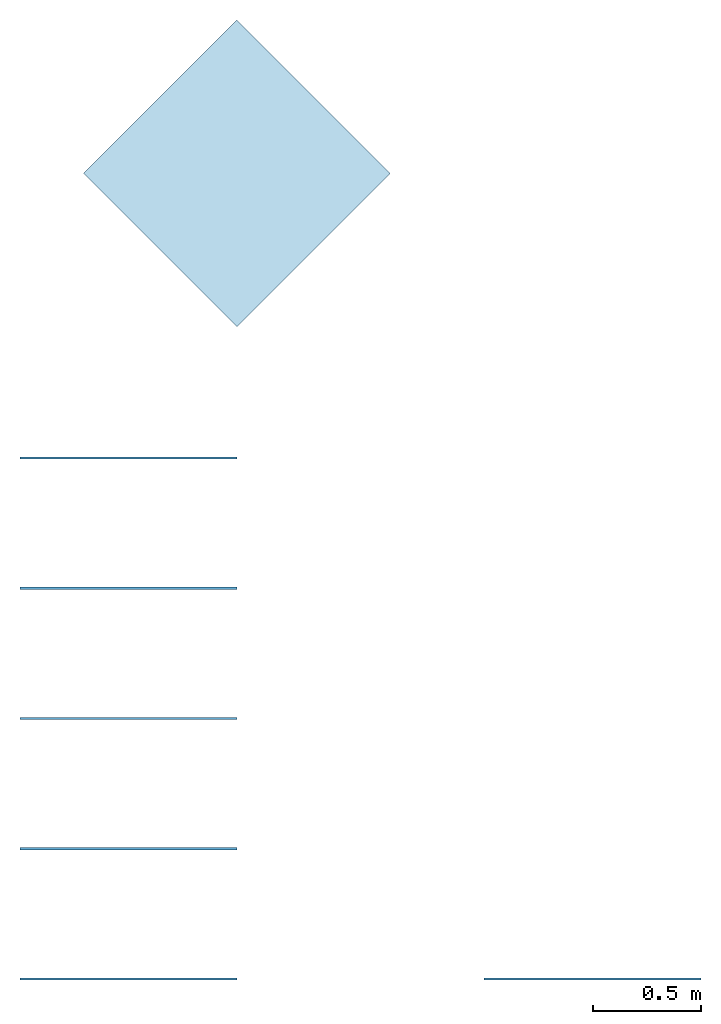
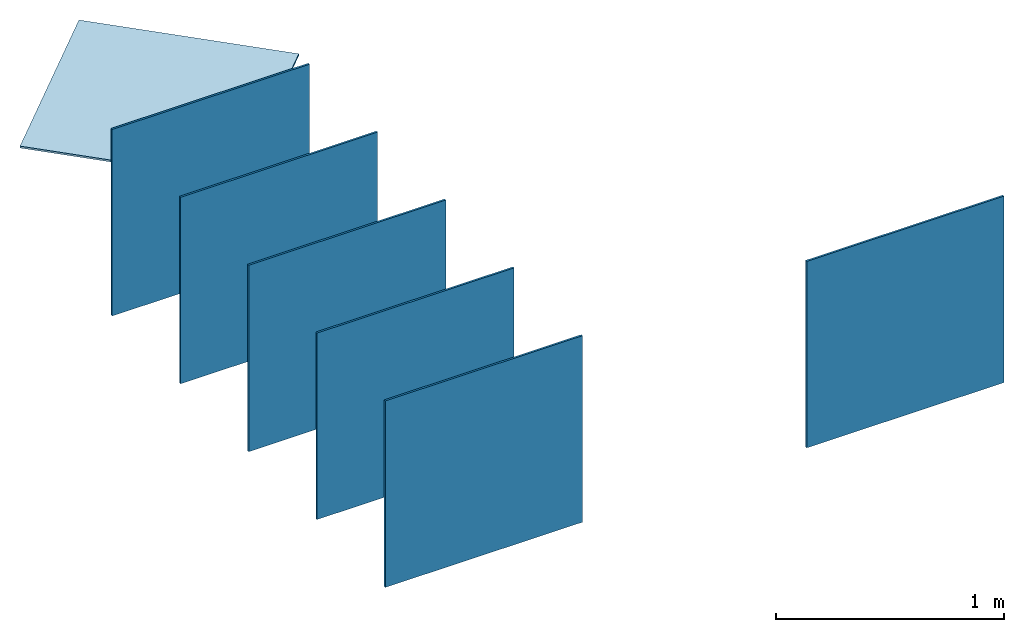
# Not in any storey: 7 plates.
"""IFC4 model written with IfcOpenShell, lengths in millimetres."""

from ifc_helpers import new_model, entity, si_unit, converted_unit, frame, frame_2d, origin_with_axes, place, context, subcontext, project, indexed_curve, outline, extrude, material, layer, layer_set, layer_usage, type_object, element, save


model = new_model("IFC4")

# Units and contexts
model_context = context("Model", 3, precision=1e-05, world=origin_with_axes())
plan_context = context("Plan", 2, precision=1e-05, world=frame_2d((0.0, 0.0, 0.0), x_axis=(1.0, 0.0, 0.0)))
body_context = subcontext(model_context, "Body", "Model", "MODEL_VIEW")
ifc_project = project(units=[converted_unit("PLANEANGLEUNIT", "degree", entity("IfcReal", 0.0174532925199433), si_unit("PLANEANGLEUNIT", "RADIAN"), dimensions=[0, 0, 0, 0, 0, 0, 0]), si_unit("AREAUNIT", "SQUARE_METRE", prefix="MILLI"), si_unit("VOLUMEUNIT", "CUBIC_METRE", prefix="MILLI"), si_unit("LENGTHUNIT", "METRE", prefix="MILLI")], contexts=[model_context, plan_context])

# Plates
ifc_material = material(Name="MDF")
ifc_layer = layer(ifc_material, 10.0, ventilated=False, Name="12mm MDF", Priority=0)
ifc_layer_set = layer_set([ifc_layer], Name="MDF12")
ifc_layer_usage_1 = layer_usage(ifc_layer_set, "AXIS3", "POSITIVE", 0.0)
plate_type = type_object("IfcPlateType", Name="MDF 12mm", PredefinedType="SHEET", material=ifc_layer_set)
plate_1_placement = place(None, frame((0.0, 2999.76062774658, -9.99999977648258), z_axis=(0.0, 0.0, 1.0), x_axis=(0.707106649875641, 0.70710676908493, 0.0)))
element("IfcPlate", 1, at=plate_1_placement, type_object=plate_type, material=ifc_layer_usage_1, Name="Plate", PredefinedType="NOTDEFINED", context=body_context, shape_type="SweptSolid", body=[
    extrude(outline(indexed_curve([(0.0, 0.0), (1000.0, 0.0), (1000.0, 1000.0), (0.0, 1000.0), (0.0, 0.0)])), None, (0.0, 0.0, 1.0), 10.0),
])
ifc_layer_usage_2 = layer_usage(ifc_layer_set, "AXIS3", "POSITIVE", 0.0)
plate_2_placement = place(None, frame((1137.71200180054, 0.0, -9.99999977648258), z_axis=(0.0, -1.0, -4.37113882867379e-08), x_axis=(1.0, 0.0, 0.0)))
element("IfcPlate", 2, at=plate_2_placement, type_object=plate_type, material=ifc_layer_usage_2, Name="Plate", PredefinedType="NOTDEFINED", context=body_context, shape_type="SweptSolid", body=[
    extrude(outline(indexed_curve([(0.0, 0.0), (1000.0, 0.0), (1000.0, 1000.0), (0.0, 1000.0), (0.0, 0.0)])), None, (0.0, 0.0, 1.0), 10.0),
])
ifc_layer_usage_3 = layer_usage(ifc_layer_set, "AXIS3", "POSITIVE", 0.0)
plate_3_placement = place(None, frame((0.0, 0.0, -9.99999977648258), z_axis=(4.37113882867379e-08, -1.0, -3.30011807777566e-15), x_axis=(7.54979012640433e-08, 0.0, 1.0)))
element("IfcPlate", 3, at=plate_3_placement, type_object=plate_type, material=ifc_layer_usage_3, Name="Plate", PredefinedType="NOTDEFINED", context=body_context, shape_type="SweptSolid", body=[
    extrude(outline(indexed_curve([(0.0, 0.0), (1000.0, 0.0), (1000.0, 1000.0), (0.0, 1000.0), (0.0, 0.0)])), None, (0.0, 0.0, 1.0), 10.0),
])
ifc_layer_usage_4 = layer_usage(ifc_layer_set, "AXIS3", "POSITIVE", 0.0)
plate_4_placement = place(None, frame((0.0, 600.000023841858, -9.99999977648258), z_axis=(4.37113882867379e-08, -1.0, -3.30011807777566e-15), x_axis=(7.54979012640433e-08, 0.0, 1.0)))
element("IfcPlate", 4, at=plate_4_placement, type_object=plate_type, material=ifc_layer_usage_4, Name="Plate", PredefinedType="NOTDEFINED", context=body_context, shape_type="SweptSolid", body=[
    extrude(outline(indexed_curve([(0.0, 0.0), (1000.0, 0.0), (1000.0, 1000.0), (0.0, 1000.0), (0.0, 0.0)])), None, (0.0, 0.0, 1.0), 10.0),
])
ifc_layer_usage_5 = layer_usage(ifc_layer_set, "AXIS3", "POSITIVE", 0.0)
plate_5_placement = place(None, frame((0.0, 1200.00004768372, -9.99999977648258), z_axis=(4.37113882867379e-08, -1.0, -3.30011807777566e-15), x_axis=(7.54979012640433e-08, 0.0, 1.0)))
element("IfcPlate", 5, at=plate_5_placement, type_object=plate_type, material=ifc_layer_usage_5, Name="Plate", PredefinedType="NOTDEFINED", context=body_context, shape_type="SweptSolid", body=[
    extrude(outline(indexed_curve([(0.0, 0.0), (1000.0, 0.0), (1000.0, 1000.0), (0.0, 1000.0), (0.0, 0.0)])), None, (0.0, 0.0, 1.0), 10.0),
])
ifc_layer_usage_6 = layer_usage(ifc_layer_set, "AXIS3", "POSITIVE", 0.0)
plate_6_placement = place(None, frame((0.0, 1799.99995231628, -9.99999977648258), z_axis=(4.37113882867379e-08, -1.0, -3.30011807777566e-15), x_axis=(7.54979012640433e-08, 0.0, 1.0)))
element("IfcPlate", 6, at=plate_6_placement, type_object=plate_type, material=ifc_layer_usage_6, Name="Plate", PredefinedType="NOTDEFINED", context=body_context, shape_type="SweptSolid", body=[
    extrude(outline(indexed_curve([(0.0, 0.0), (1000.0, 0.0), (1000.0, 1000.0), (0.0, 1000.0), (0.0, 0.0)])), None, (0.0, 0.0, 1.0), 10.0),
])
ifc_layer_usage_7 = layer_usage(ifc_layer_set, "AXIS3", "POSITIVE", 0.0)
plate_7_placement = place(None, frame((0.0, 2400.00009536743, -9.99999977648258), z_axis=(4.37113882867379e-08, -1.0, -3.30011807777566e-15), x_axis=(7.54979012640433e-08, 0.0, 1.0)))
element("IfcPlate", 7, at=plate_7_placement, type_object=plate_type, material=ifc_layer_usage_7, Name="Plate", PredefinedType="NOTDEFINED", context=body_context, shape_type="SweptSolid", body=[
    extrude(outline(indexed_curve([(0.0, 0.0), (1000.0, 0.0), (1000.0, 1000.0), (0.0, 1000.0), (0.0, 0.0)])), None, (0.0, 0.0, 1.0), 10.0),
])

save(model, "model.ifc")
